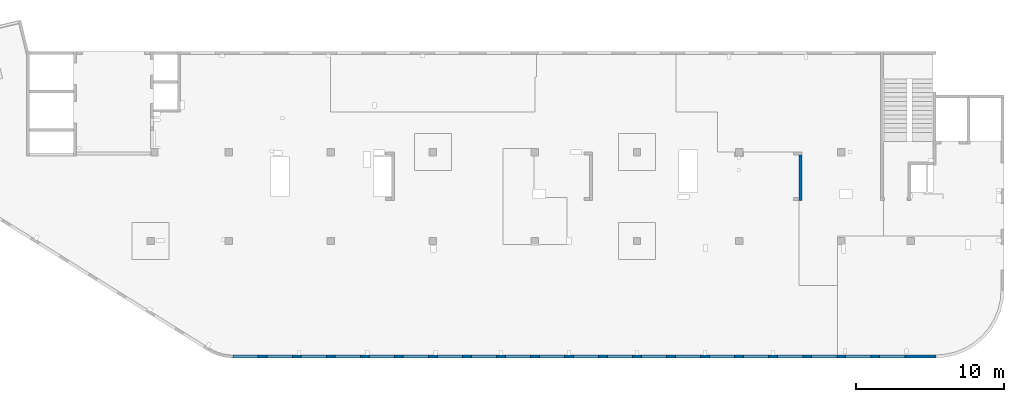
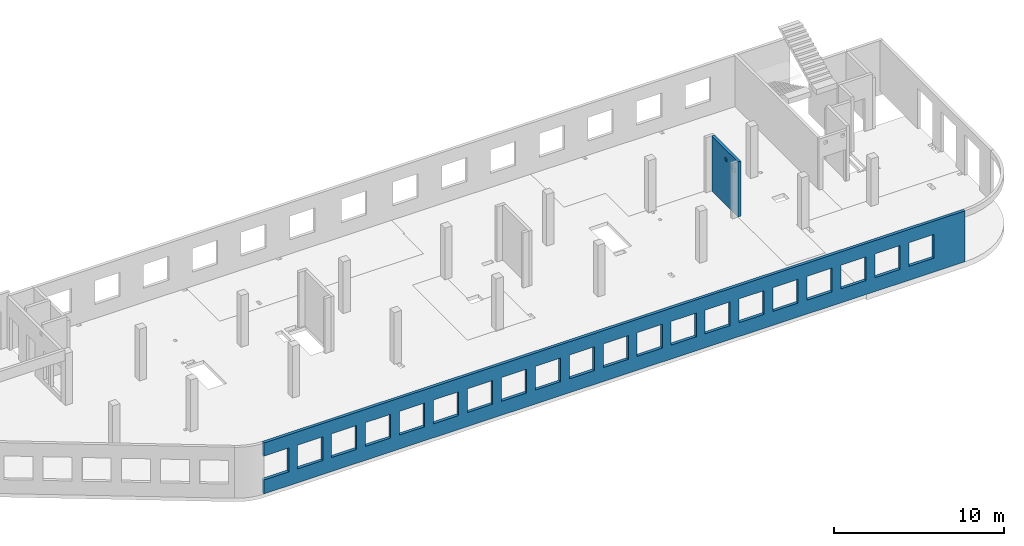
# One storey, part 5 of 6: 2 walls, 22 openings.
"""IFC4 building model written with IfcOpenShell, lengths in millimetres."""

from ifc_helpers import new_model, entity, si_unit, converted_unit, derived_unit, direction, frame, origin, place, context, subcontext, project, spatial, indexed_curve, outline, extrude, polygons, material, type_object, element, save


model = new_model("IFC4")

# Units and contexts
model_context = context("Model", 3, precision=0.01, world=origin(), true_north=direction((6.12303176911189e-17, 1.0)))
plan_context = context("Plan", 3, precision=0.01, world=origin(), true_north=direction((6.12303176911189e-17, 1.0)))
body_context = subcontext(model_context, "Body", "Model", "MODEL_VIEW")
ifc_project = project(units=[si_unit("LENGTHUNIT", "METRE", prefix="MILLI"), si_unit("AREAUNIT", "SQUARE_METRE"), si_unit("VOLUMEUNIT", "CUBIC_METRE"), converted_unit("PLANEANGLEUNIT", "DEGREE", entity("IfcRatioMeasure", 0.0174532925199433), si_unit("PLANEANGLEUNIT", "RADIAN"), dimensions=[0, 0, 0, 0, 0, 0, 0]), si_unit("MASSUNIT", "GRAM", prefix="KILO"), derived_unit("MASSDENSITYUNIT", [(si_unit("MASSUNIT", "GRAM", prefix="KILO"), 1), (si_unit("LENGTHUNIT", "METRE"), -3)]), derived_unit("MOMENTOFINERTIAUNIT", [(si_unit("LENGTHUNIT", "METRE"), 4)]), si_unit("TIMEUNIT", "SECOND"), si_unit("FREQUENCYUNIT", "HERTZ"), si_unit("THERMODYNAMICTEMPERATUREUNIT", "DEGREE_CELSIUS"), derived_unit("THERMALTRANSMITTANCEUNIT", [(si_unit("MASSUNIT", "GRAM", prefix="KILO"), 1), (si_unit("THERMODYNAMICTEMPERATUREUNIT", "KELVIN"), -1), (si_unit("TIMEUNIT", "SECOND"), -3)]), derived_unit("VOLUMETRICFLOWRATEUNIT", [(si_unit("LENGTHUNIT", "METRE"), 3), (si_unit("TIMEUNIT", "SECOND"), -1)]), derived_unit("MASSFLOWRATEUNIT", [(si_unit("MASSUNIT", "GRAM", prefix="KILO"), 1), (si_unit("TIMEUNIT", "SECOND"), -1)]), derived_unit("ROTATIONALFREQUENCYUNIT", [(si_unit("TIMEUNIT", "SECOND"), -1)]), si_unit("ELECTRICCURRENTUNIT", "AMPERE"), si_unit("ELECTRICVOLTAGEUNIT", "VOLT"), si_unit("POWERUNIT", "WATT"), si_unit("FORCEUNIT", "NEWTON", prefix="KILO"), si_unit("ILLUMINANCEUNIT", "LUX"), si_unit("LUMINOUSFLUXUNIT", "LUMEN"), si_unit("LUMINOUSINTENSITYUNIT", "CANDELA"), derived_unit("USERDEFINED", [(si_unit("MASSUNIT", "GRAM", prefix="KILO"), -1), (si_unit("LENGTHUNIT", "METRE"), -2), (si_unit("TIMEUNIT", "SECOND"), 3), (si_unit("LUMINOUSFLUXUNIT", "LUMEN"), 1)]), derived_unit("LINEARVELOCITYUNIT", [(si_unit("LENGTHUNIT", "METRE"), 1), (si_unit("TIMEUNIT", "SECOND"), -1)]), si_unit("PRESSUREUNIT", "PASCAL"), derived_unit("USERDEFINED", [(si_unit("LENGTHUNIT", "METRE"), -2), (si_unit("MASSUNIT", "GRAM", prefix="KILO"), 1), (si_unit("TIMEUNIT", "SECOND"), -2)]), derived_unit("LINEARFORCEUNIT", [(si_unit("MASSUNIT", "GRAM", prefix="KILO"), 1), (si_unit("LENGTHUNIT", "METRE"), 1), (si_unit("TIMEUNIT", "SECOND"), -2), (si_unit("LENGTHUNIT", "METRE"), -1)]), derived_unit("PLANARFORCEUNIT", [(si_unit("MASSUNIT", "GRAM", prefix="KILO"), 1), (si_unit("LENGTHUNIT", "METRE"), 1), (si_unit("TIMEUNIT", "SECOND"), -2), (si_unit("LENGTHUNIT", "METRE"), -2)])], contexts=[model_context, plan_context])

# Site, building, storey
site_placement = place(None, origin())
site = spatial("IfcSite", under=ifc_project, at=site_placement, CompositionType="ELEMENT")
building_placement = place(site_placement, origin())
building = spatial("IfcBuilding", under=site, at=building_placement, CompositionType="ELEMENT")
storey_placement = place(building_placement, frame((0.0, 0.0, 8100.0)))
storey = spatial("IfcBuildingStorey", under=building, at=storey_placement, Name="03", CompositionType="ELEMENT", Elevation=8100.0)

# Wall, openings
ifc_material = material()
wall_type = type_object("IfcWallType", Name=":ADSK_ 25_200", PredefinedType="STANDARD")
wall_1_placement = place(storey_placement, frame((68970.0, -100.0, -150.0), z_axis=(0.0, 0.0, 1.0), x_axis=(-1.0, 0.0, 0.0)))
wall_1 = element("IfcWall", 1, at=wall_1_placement, inside=storey, type_object=wall_type, material=ifc_material, Name=":ADSK_ 25_200", ObjectType=":ADSK_ 25_200", PredefinedType="NOTDEFINED", context=body_context, shape_type="Tessellation", body=[
    polygons([(43500.0, -100.000000000321, 2700.0), (45200.0, -100.000000000321, 2700.0), (45200.0, -100.000000000321, 1000.00000000001), (43500.0, -100.000000000321, 1000.00000000001), (41200.0, -100.000000000321, 2700.0), (42900.0, -100.000000000321, 2700.0), (42900.0, -100.000000000321, 1000.00000000001), (41200.0, -100.000000000321, 1000.00000000001), (38900.0, -100.000000000321, 2700.0), (40600.0, -100.000000000321, 2700.0), (40600.0, -100.000000000321, 1000.00000000001), (38900.0, -100.000000000321, 1000.00000000001), (36600.0, -100.000000000321, 2700.0), (38300.0, -100.000000000321, 2700.0), (38300.0, -100.000000000321, 1000.00000000001), (36600.0, -100.000000000321, 1000.00000000001), (34300.0, -100.000000000321, 2700.0), (36000.0, -100.000000000321, 2700.0), (36000.0, -100.000000000321, 1000.00000000001), (34300.0, -100.000000000321, 1000.00000000001), (32000.0, -100.000000000321, 2700.0), (33700.0, -100.000000000321, 2700.0), (33700.0, -100.000000000321, 1000.00000000001), (32000.0, -100.000000000321, 1000.00000000001), (29700.0, -100.000000000321, 2700.0), (31400.0, -100.000000000321, 2700.0), (31400.0, -100.000000000321, 1000.00000000001), (29700.0, -100.000000000321, 1000.00000000001), (27400.0, -100.000000000321, 2700.0), (29100.0, -100.000000000321, 2700.0), (29100.0, -100.000000000321, 1000.00000000001), (27400.0, -100.000000000321, 1000.00000000001), (25100.0, -100.000000000321, 2700.0), (26800.0, -100.000000000321, 2700.0), (26800.0, -100.000000000321, 1000.00000000001), (25100.0, -100.000000000321, 1000.00000000001), (22800.0, -100.000000000321, 2700.0), (24500.0, -100.000000000321, 2700.0), (24500.0, -100.000000000321, 1000.00000000001), (22800.0, -100.000000000321, 1000.00000000001), (20500.0, -100.000000000321, 2700.0), (22200.0, -100.000000000321, 2700.0), (22200.0, -100.000000000321, 1000.00000000001), (20500.0, -100.000000000321, 1000.00000000001), (18200.0, -100.000000000321, 2700.0), (19900.0, -100.000000000321, 2700.0), (19900.0, -100.000000000321, 1000.00000000001), (18200.0, -100.000000000321, 1000.00000000001), (15900.0, -100.000000000321, 2700.0), (17600.0, -100.000000000321, 2700.0), (17600.0, -100.000000000321, 1000.00000000001), (15900.0, -100.000000000321, 1000.00000000001), (13600.0, -100.000000000321, 2700.0), (15300.0, -100.000000000321, 2700.0), (15300.0, -100.000000000321, 1000.00000000001), (13600.0, -100.000000000321, 1000.00000000001), (11300.0, -100.000000000321, 2700.0), (13000.0, -100.000000000321, 2700.0), (13000.0, -100.000000000321, 1000.00000000001), (11300.0, -100.000000000321, 1000.00000000001), (8999.99999999998, -100.000000000321, 2700.0), (10700.0, -100.000000000321, 2700.0), (10700.0, -100.000000000321, 1000.00000000001), (8999.99999999998, -100.000000000321, 1000.00000000001), (6699.99999999998, -100.000000000321, 2700.0), (8399.99999999997, -100.000000000321, 2700.0), (8399.99999999997, -100.000000000321, 1000.00000000001), (6699.99999999998, -100.000000000321, 1000.00000000001), (4399.99999999998, -100.000000000321, 2700.0), (6099.99999999997, -100.000000000321, 2700.0), (6099.99999999997, -100.000000000321, 1000.00000000001), (4399.99999999998, -100.000000000321, 1000.00000000001), (2099.99999999998, -100.000000000321, 2700.0), (3799.99999999998, -100.000000000321, 2700.0), (3799.99999999998, -100.000000000321, 1000.00000000001), (2099.99999999998, -100.000000000321, 1000.00000000001), (8.66293717728731e-12, -100.0, 0.0), (10900.0003342008, -100.0, 0.0), (11100.0003342008, -100.0, 0.0), (15500.0003342008, -100.0, 0.0), (15700.0003342008, -100.0, 0.0), (20100.0, -100.0, 0.0), (20300.0, -100.0, 0.0), (24700.0003342008, -100.0, 0.0), (24900.0003342008, -100.0, 0.0), (38320.0003342008, -100.0, 0.0), (38520.0003342008, -100.0, 0.0), (42930.0, -100.0, 0.0), (43130.0, -100.0, 0.0), (47500.0, -100.0, 0.0), (47500.0, -100.0, 1000.00000000001), (45800.0, -100.000000000321, 1000.00000000001), (45800.0, -100.000000000321, 2700.0), (47500.0, -100.0, 2700.0), (47500.0, -100.0, 3650.0), (8.66293717728731e-12, -100.0, 3650.0), (1.42900165493394e-19, -100.0, 3200.0), (47500.0, 100.0, 0.0), (8.01671852045731e-12, 100.0, 0.0), (-6.46218513929826e-13, 100.0, 3200.0), (8.01671852045731e-12, 100.0, 3650.0), (47500.0, 100.0, 3650.0), (47500.0, 100.0, 2700.0), (45800.0, 100.0, 2700.0), (45800.0, 100.0, 1000.00000000001), (47500.0, 100.0, 1000.00000000001), (45200.0, 100.0, 2700.0), (43500.0, 100.0, 2700.0), (43500.0, 100.0, 1000.00000000001), (45200.0, 100.0, 1000.00000000001), (42900.0, 100.0, 2700.0), (41200.0, 100.0, 2700.0), (41200.0, 100.0, 1000.00000000001), (42900.0, 100.0, 1000.00000000001), (40600.0, 100.0, 2700.0), (38900.0, 100.0, 2700.0), (38900.0, 100.0, 1000.00000000001), (40600.0, 100.0, 1000.00000000001), (38300.0, 100.0, 2700.0), (36600.0, 100.0, 2700.0), (36600.0, 100.0, 1000.00000000001), (38300.0, 100.0, 1000.00000000001), (36000.0, 100.0, 2700.0), (34300.0, 100.0, 2700.0), (34300.0, 100.0, 1000.00000000001), (36000.0, 100.0, 1000.00000000001), (33700.0, 100.0, 2700.0), (32000.0, 100.0, 2700.0), (32000.0, 100.0, 1000.00000000001), (33700.0, 100.0, 1000.00000000001), (31400.0, 100.0, 2700.0), (29700.0, 100.0, 2700.0), (29700.0, 100.0, 1000.00000000001), (31400.0, 100.0, 1000.00000000001), (29100.0, 100.0, 2700.0), (27400.0, 100.0, 2700.0), (27400.0, 100.0, 1000.00000000001), (29100.0, 100.0, 1000.00000000001), (26800.0, 100.0, 2700.0), (25100.0, 100.0, 2700.0), (25100.0, 100.0, 1000.00000000001), (26800.0, 100.0, 1000.00000000001), (24500.0, 100.0, 2700.0), (22800.0, 100.0, 2700.0), (22800.0, 100.0, 1000.00000000001), (24500.0, 100.0, 1000.00000000001), (22200.0, 100.0, 2700.0), (20500.0, 100.0, 2700.0), (20500.0, 100.0, 1000.00000000001), (22200.0, 100.0, 1000.00000000001), (19900.0, 100.0, 2700.0), (18200.0, 100.0, 2700.0), (18200.0, 100.0, 1000.00000000001), (19900.0, 100.0, 1000.00000000001), (17600.0, 100.0, 2700.0), (15900.0, 100.0, 2700.0), (15900.0, 100.0, 1000.00000000001), (17600.0, 100.0, 1000.00000000001), (15300.0, 100.0, 2700.0), (13600.0, 100.0, 2700.0), (13600.0, 100.0, 1000.00000000001), (15300.0, 100.0, 1000.00000000001), (13000.0, 100.0, 2700.0), (11300.0, 100.0, 2700.0), (11300.0, 100.0, 1000.00000000001), (13000.0, 100.0, 1000.00000000001), (10700.0, 100.0, 2700.0), (8999.99999999998, 100.0, 2700.0), (8999.99999999998, 100.0, 1000.00000000001), (10700.0, 100.0, 1000.00000000001), (8399.99999999997, 100.0, 2700.0), (6699.99999999997, 100.0, 2700.0), (6699.99999999997, 100.0, 1000.00000000001), (8399.99999999997, 100.0, 1000.00000000001), (6099.99999999997, 100.0, 2700.0), (4399.99999999998, 100.0, 2700.0), (4399.99999999998, 100.0, 1000.00000000001), (6099.99999999997, 100.0, 1000.00000000001), (3799.99999999998, 100.0, 2700.0), (2099.99999999998, 100.0, 2700.0), (2099.99999999998, 100.0, 1000.00000000001), (3799.99999999998, 100.0, 1000.00000000001)], [[[77, 78, 79, 80, 81, 82, 83, 84, 85, 86, 87, 88, 89, 90, 91, 92, 93, 94, 95, 96, 97], [1, 2, 3, 4], [5, 6, 7, 8], [9, 10, 11, 12], [13, 14, 15, 16], [17, 18, 19, 20], [21, 22, 23, 24], [25, 26, 27, 28], [29, 30, 31, 32], [33, 34, 35, 36], [37, 38, 39, 40], [41, 42, 43, 44], [45, 46, 47, 48], [49, 50, 51, 52], [53, 54, 55, 56], [57, 58, 59, 60], [61, 62, 63, 64], [65, 66, 67, 68], [69, 70, 71, 72], [73, 74, 75, 76]], [[98, 99, 100, 101, 102, 103, 104, 105, 106], [107, 108, 109, 110], [111, 112, 113, 114], [115, 116, 117, 118], [119, 120, 121, 122], [123, 124, 125, 126], [127, 128, 129, 130], [131, 132, 133, 134], [135, 136, 137, 138], [139, 140, 141, 142], [143, 144, 145, 146], [147, 148, 149, 150], [151, 152, 153, 154], [155, 156, 157, 158], [159, 160, 161, 162], [163, 164, 165, 166], [167, 168, 169, 170], [171, 172, 173, 174], [175, 176, 177, 178], [179, 180, 181, 182]], [[90, 89, 88, 87, 86, 85, 84, 83, 82, 81, 80, 79, 78, 77, 99, 98]], [[90, 98, 106, 91]], [[96, 95, 102, 101]], [[77, 97, 96, 101, 100, 99]], [[93, 104, 103, 94]], [[105, 92, 91, 106]], [[104, 93, 92, 105]], [[2, 1, 108, 107]], [[2, 107, 110, 3]], [[3, 110, 109, 4]], [[108, 1, 4, 109]], [[6, 5, 112, 111]], [[6, 111, 114, 7]], [[7, 114, 113, 8]], [[112, 5, 8, 113]], [[10, 9, 116, 115]], [[10, 115, 118, 11]], [[11, 118, 117, 12]], [[116, 9, 12, 117]], [[14, 13, 120, 119]], [[14, 119, 122, 15]], [[15, 122, 121, 16]], [[120, 13, 16, 121]], [[18, 17, 124, 123]], [[18, 123, 126, 19]], [[19, 126, 125, 20]], [[124, 17, 20, 125]], [[22, 21, 128, 127]], [[22, 127, 130, 23]], [[23, 130, 129, 24]], [[128, 21, 24, 129]], [[26, 25, 132, 131]], [[26, 131, 134, 27]], [[27, 134, 133, 28]], [[132, 25, 28, 133]], [[30, 29, 136, 135]], [[30, 135, 138, 31]], [[31, 138, 137, 32]], [[136, 29, 32, 137]], [[34, 33, 140, 139]], [[34, 139, 142, 35]], [[35, 142, 141, 36]], [[140, 33, 36, 141]], [[38, 37, 144, 143]], [[38, 143, 146, 39]], [[39, 146, 145, 40]], [[144, 37, 40, 145]], [[42, 41, 148, 147]], [[42, 147, 150, 43]], [[43, 150, 149, 44]], [[148, 41, 44, 149]], [[46, 45, 152, 151]], [[46, 151, 154, 47]], [[47, 154, 153, 48]], [[152, 45, 48, 153]], [[50, 49, 156, 155]], [[50, 155, 158, 51]], [[51, 158, 157, 52]], [[156, 49, 52, 157]], [[54, 53, 160, 159]], [[54, 159, 162, 55]], [[55, 162, 161, 56]], [[160, 53, 56, 161]], [[58, 57, 164, 163]], [[58, 163, 166, 59]], [[59, 166, 165, 60]], [[164, 57, 60, 165]], [[62, 61, 168, 167]], [[62, 167, 170, 63]], [[63, 170, 169, 64]], [[168, 61, 64, 169]], [[66, 65, 172, 171]], [[66, 171, 174, 67]], [[67, 174, 173, 68]], [[172, 65, 68, 173]], [[70, 69, 176, 175]], [[70, 175, 178, 71]], [[71, 178, 177, 72]], [[176, 69, 72, 177]], [[74, 73, 180, 179]], [[74, 179, 182, 75]], [[75, 182, 181, 76]], [[180, 73, 76, 181]], [[102, 95, 94, 103]]], closed=True),
])
placement_1 = place(wall_1_placement, frame((68970.0, -100.0, 150.0), z_axis=(0.0, 0.0, 1.0), x_axis=(-1.0, 0.0, 0.0)))
element("IfcOpeningElement", 2, at=placement_1, cuts=wall_1, Name=":ADSK_ 25_200", PredefinedType="OPENING", context=body_context, shape_type="SweptSolid", body=[
    extrude(outline(indexed_curve([(-850.000000000002, -849.999999999995), (849.999999999997, -849.999999999995), (849.999999999997, 849.999999999993), (-850.000000000002, 849.999999999993), (-850.000000000002, -849.999999999995)], self_intersect=False)), frame((22320.0, 0.0, 1700.0), z_axis=(0.0, -1.0, 0.0), x_axis=(-1.0, 0.0, 0.0)), (0.0, 0.0, 1.0), 200.000000000962),
])
element("IfcOpeningElement", 3, at=placement_1, cuts=wall_1, Name=":ADSK_ 25_200", PredefinedType="OPENING", context=body_context, shape_type="SweptSolid", body=[
    extrude(outline(indexed_curve([(-849.999999999997, -849.999999999995), (850.000000000006, -849.999999999995), (850.000000000006, 849.999999999993), (-849.999999999997, 849.999999999993), (-849.999999999997, -849.999999999995)], self_intersect=False)), frame((66020.0, 0.0, 1700.0), z_axis=(0.0, -1.0, 0.0), x_axis=(-1.0, 0.0, 0.0)), (0.0, 0.0, 1.0), 200.000000000962),
])
element("IfcOpeningElement", 4, at=placement_1, cuts=wall_1, Name=":ADSK_ 25_200", PredefinedType="OPENING", context=body_context, shape_type="SweptSolid", body=[
    extrude(outline(indexed_curve([(-849.999999999997, -849.999999999995), (850.000000000006, -849.999999999995), (850.000000000006, 849.999999999993), (-849.999999999997, 849.999999999993), (-849.999999999997, -849.999999999995)], self_intersect=False)), frame((63720.0, 0.0, 1700.0), z_axis=(0.0, -1.0, 0.0), x_axis=(-1.0, 0.0, 0.0)), (0.0, 0.0, 1.0), 200.000000000962),
])
element("IfcOpeningElement", 5, at=placement_1, cuts=wall_1, Name=":ADSK_ 25_200", PredefinedType="OPENING", context=body_context, shape_type="SweptSolid", body=[
    extrude(outline(indexed_curve([(-849.999999999997, -849.999999999995), (850.000000000006, -849.999999999995), (850.000000000006, 849.999999999993), (-849.999999999997, 849.999999999993), (-849.999999999997, -849.999999999995)], self_intersect=False)), frame((61420.0, 0.0, 1700.0), z_axis=(0.0, -1.0, 0.0), x_axis=(-1.0, 0.0, 0.0)), (0.0, 0.0, 1.0), 200.000000000962),
])
element("IfcOpeningElement", 6, at=placement_1, cuts=wall_1, Name=":ADSK_ 25_200", PredefinedType="OPENING", context=body_context, shape_type="SweptSolid", body=[
    extrude(outline(indexed_curve([(-849.999999999997, -849.999999999995), (850.000000000006, -849.999999999995), (850.000000000006, 849.999999999993), (-849.999999999997, 849.999999999993), (-849.999999999997, -849.999999999995)], self_intersect=False)), frame((59120.0, 0.0, 1700.0), z_axis=(0.0, -1.0, 0.0), x_axis=(-1.0, 0.0, 0.0)), (0.0, 0.0, 1.0), 200.000000000962),
])
element("IfcOpeningElement", 7, at=placement_1, cuts=wall_1, Name=":ADSK_ 25_200", PredefinedType="OPENING", context=body_context, shape_type="SweptSolid", body=[
    extrude(outline(indexed_curve([(-849.999999999997, -849.999999999995), (850.000000000006, -849.999999999995), (850.000000000006, 849.999999999993), (-849.999999999997, 849.999999999993), (-849.999999999997, -849.999999999995)], self_intersect=False)), frame((56820.0, 0.0, 1700.0), z_axis=(0.0, -1.0, 0.0), x_axis=(-1.0, 0.0, 0.0)), (0.0, 0.0, 1.0), 200.000000000962),
])
element("IfcOpeningElement", 8, at=placement_1, cuts=wall_1, Name=":ADSK_ 25_200", PredefinedType="OPENING", context=body_context, shape_type="SweptSolid", body=[
    extrude(outline(indexed_curve([(-849.999999999997, -849.999999999995), (850.000000000006, -849.999999999995), (850.000000000006, 849.999999999993), (-849.999999999997, 849.999999999993), (-849.999999999997, -849.999999999995)], self_intersect=False)), frame((54520.0, 0.0, 1700.0), z_axis=(0.0, -1.0, 0.0), x_axis=(-1.0, 0.0, 0.0)), (0.0, 0.0, 1.0), 200.000000000962),
])
element("IfcOpeningElement", 9, at=placement_1, cuts=wall_1, Name=":ADSK_ 25_200", PredefinedType="OPENING", context=body_context, shape_type="SweptSolid", body=[
    extrude(outline(indexed_curve([(-849.999999999997, -849.999999999995), (850.000000000006, -849.999999999995), (850.000000000006, 849.999999999993), (-849.999999999997, 849.999999999993), (-849.999999999997, -849.999999999995)], self_intersect=False)), frame((52220.0, 0.0, 1700.0), z_axis=(0.0, -1.0, 0.0), x_axis=(-1.0, 0.0, 0.0)), (0.0, 0.0, 1.0), 200.000000000962),
])
element("IfcOpeningElement", 10, at=placement_1, cuts=wall_1, Name=":ADSK_ 25_200", PredefinedType="OPENING", context=body_context, shape_type="SweptSolid", body=[
    extrude(outline(indexed_curve([(-849.999999999997, -849.999999999995), (850.000000000006, -849.999999999995), (850.000000000006, 849.999999999993), (-849.999999999997, 849.999999999993), (-849.999999999997, -849.999999999995)], self_intersect=False)), frame((49920.0, 0.0, 1700.0), z_axis=(0.0, -1.0, 0.0), x_axis=(-1.0, 0.0, 0.0)), (0.0, 0.0, 1.0), 200.000000000962),
])
element("IfcOpeningElement", 11, at=placement_1, cuts=wall_1, Name=":ADSK_ 25_200", PredefinedType="OPENING", context=body_context, shape_type="SweptSolid", body=[
    extrude(outline(indexed_curve([(-849.999999999997, -849.999999999995), (850.000000000006, -849.999999999995), (850.000000000006, 849.999999999993), (-849.999999999997, 849.999999999993), (-849.999999999997, -849.999999999995)], self_intersect=False)), frame((47620.0, 0.0, 1700.0), z_axis=(0.0, -1.0, 0.0), x_axis=(-1.0, 0.0, 0.0)), (0.0, 0.0, 1.0), 200.000000000962),
])
element("IfcOpeningElement", 12, at=placement_1, cuts=wall_1, Name=":ADSK_ 25_200", PredefinedType="OPENING", context=body_context, shape_type="SweptSolid", body=[
    extrude(outline(indexed_curve([(-849.999999999997, -849.999999999995), (850.000000000006, -849.999999999995), (850.000000000006, 849.999999999993), (-849.999999999997, 849.999999999993), (-849.999999999997, -849.999999999995)], self_intersect=False)), frame((45320.0, 0.0, 1700.0), z_axis=(0.0, -1.0, 0.0), x_axis=(-1.0, 0.0, 0.0)), (0.0, 0.0, 1.0), 200.000000000962),
])
element("IfcOpeningElement", 13, at=placement_1, cuts=wall_1, Name=":ADSK_ 25_200", PredefinedType="OPENING", context=body_context, shape_type="SweptSolid", body=[
    extrude(outline(indexed_curve([(-849.999999999997, -849.999999999995), (850.000000000006, -849.999999999995), (850.000000000006, 849.999999999993), (-849.999999999997, 849.999999999993), (-849.999999999997, -849.999999999995)], self_intersect=False)), frame((43020.0, 0.0, 1700.0), z_axis=(0.0, -1.0, 0.0), x_axis=(-1.0, 0.0, 0.0)), (0.0, 0.0, 1.0), 200.000000000962),
])
element("IfcOpeningElement", 14, at=placement_1, cuts=wall_1, Name=":ADSK_ 25_200", PredefinedType="OPENING", context=body_context, shape_type="SweptSolid", body=[
    extrude(outline(indexed_curve([(-849.999999999997, -849.999999999995), (850.000000000006, -849.999999999995), (850.000000000006, 849.999999999993), (-849.999999999997, 849.999999999993), (-849.999999999997, -849.999999999995)], self_intersect=False)), frame((40720.0, 0.0, 1700.0), z_axis=(0.0, -1.0, 0.0), x_axis=(-1.0, 0.0, 0.0)), (0.0, 0.0, 1.0), 200.000000000962),
])
element("IfcOpeningElement", 15, at=placement_1, cuts=wall_1, Name=":ADSK_ 25_200", PredefinedType="OPENING", context=body_context, shape_type="SweptSolid", body=[
    extrude(outline(indexed_curve([(-849.999999999997, -849.999999999995), (850.000000000002, -849.999999999995), (850.000000000002, 849.999999999993), (-849.999999999997, 849.999999999993), (-849.999999999997, -849.999999999995)], self_intersect=False)), frame((38420.0, 0.0, 1700.0), z_axis=(0.0, -1.0, 0.0), x_axis=(-1.0, 0.0, 0.0)), (0.0, 0.0, 1.0), 200.000000000962),
])
element("IfcOpeningElement", 16, at=placement_1, cuts=wall_1, Name=":ADSK_ 25_200", PredefinedType="OPENING", context=body_context, shape_type="SweptSolid", body=[
    extrude(outline(indexed_curve([(-849.999999999997, -849.999999999995), (850.000000000002, -849.999999999995), (850.000000000002, 849.999999999993), (-849.999999999997, 849.999999999993), (-849.999999999997, -849.999999999995)], self_intersect=False)), frame((36120.0, 0.0, 1700.0), z_axis=(0.0, -1.0, 0.0), x_axis=(-1.0, 0.0, 0.0)), (0.0, 0.0, 1.0), 200.000000000962),
])
element("IfcOpeningElement", 17, at=placement_1, cuts=wall_1, Name=":ADSK_ 25_200", PredefinedType="OPENING", context=body_context, shape_type="SweptSolid", body=[
    extrude(outline(indexed_curve([(-849.999999999997, -849.999999999995), (850.000000000002, -849.999999999995), (850.000000000002, 849.999999999993), (-849.999999999997, 849.999999999993), (-849.999999999997, -849.999999999995)], self_intersect=False)), frame((33820.0, 0.0, 1700.0), z_axis=(0.0, -1.0, 0.0), x_axis=(-1.0, 0.0, 0.0)), (0.0, 0.0, 1.0), 200.000000000962),
])
element("IfcOpeningElement", 18, at=placement_1, cuts=wall_1, Name=":ADSK_ 25_200", PredefinedType="OPENING", context=body_context, shape_type="SweptSolid", body=[
    extrude(outline(indexed_curve([(-849.999999999997, -849.999999999995), (850.000000000002, -849.999999999995), (850.000000000002, 849.999999999993), (-849.999999999997, 849.999999999993), (-849.999999999997, -849.999999999995)], self_intersect=False)), frame((31520.0, 0.0, 1700.0), z_axis=(0.0, -1.0, 0.0), x_axis=(-1.0, 0.0, 0.0)), (0.0, 0.0, 1.0), 200.000000000962),
])
element("IfcOpeningElement", 19, at=placement_1, cuts=wall_1, Name=":ADSK_ 25_200", PredefinedType="OPENING", context=body_context, shape_type="SweptSolid", body=[
    extrude(outline(indexed_curve([(-850.000000000002, -849.999999999995), (849.999999999997, -849.999999999995), (849.999999999997, 849.999999999993), (-850.000000000002, 849.999999999993), (-850.000000000002, -849.999999999995)], self_intersect=False)), frame((29220.0, 0.0, 1700.0), z_axis=(0.0, -1.0, 0.0), x_axis=(-1.0, 0.0, 0.0)), (0.0, 0.0, 1.0), 200.000000000962),
])
element("IfcOpeningElement", 20, at=placement_1, cuts=wall_1, Name=":ADSK_ 25_200", PredefinedType="OPENING", context=body_context, shape_type="SweptSolid", body=[
    extrude(outline(indexed_curve([(-850.000000000002, -849.999999999995), (849.999999999997, -849.999999999995), (849.999999999997, 849.999999999993), (-850.000000000002, 849.999999999993), (-850.000000000002, -849.999999999995)], self_intersect=False)), frame((26920.0, 0.0, 1700.0), z_axis=(0.0, -1.0, 0.0), x_axis=(-1.0, 0.0, 0.0)), (0.0, 0.0, 1.0), 200.000000000962),
])
element("IfcOpeningElement", 21, at=placement_1, cuts=wall_1, Name=":ADSK_ 25_200", PredefinedType="OPENING", context=body_context, shape_type="SweptSolid", body=[
    extrude(outline(indexed_curve([(-850.000000000002, -849.999999999995), (849.999999999997, -849.999999999995), (849.999999999997, 849.999999999993), (-850.000000000002, 849.999999999993), (-850.000000000002, -849.999999999995)], self_intersect=False)), frame((24620.0, 0.0, 1700.0), z_axis=(0.0, -1.0, 0.0), x_axis=(-1.0, 0.0, 0.0)), (0.0, 0.0, 1.0), 200.000000000962),
])

wall_2_placement = place(storey_placement, frame((59830.0, 13500.0, -150.0), z_axis=(0.0, 0.0, 1.0), x_axis=(0.0, -1.0, 0.0)))
wall_2 = element("IfcWall", 22, at=wall_2_placement, inside=storey, type_object=wall_type, material=ifc_material, Name=":ADSK_ 25_200", ObjectType=":ADSK_ 25_200", PredefinedType="NOTDEFINED", context=body_context, shape_type="Tessellation", body=[
    polygons([(-2.16573425859679e-12, -99.999999999987, 0.0), (2875.00000000001, -99.9999999999967, 0.0), (3075.00000000001, -99.9999999999962, 0.0), (3075.00000000001, -99.9999999999962, 3950.0), (2875.00000000001, -99.9999999999967, 3950.0), (-2.16573425859679e-12, -99.999999999987, 3950.0), (1560.00000000001, -100.000000000009, 3400.0), (1810.00000000001, -100.000000000008, 3400.0), (1810.00000000001, -100.000000000008, 3150.00000000001), (1560.00000000001, -100.000000000009, 3150.00000000001), (2360.00000000001, -100.000000000007, 3330.0), (2710.00000000001, -100.000000000006, 3330.0), (2710.00000000001, -100.000000000006, 2980.00000000001), (2360.00000000001, -100.000000000007, 2980.00000000001), (-2.16573425859679e-12, 100.000000000002, 0.0), (-2.16573425859679e-12, 100.000000000002, 3950.0), (3075.00000000001, 99.999999999993, 3950.0), (3075.00000000001, 99.999999999993, 0.0), (1810.00000000001, 100.000000000319, 3400.0), (1560.00000000001, 100.000000000318, 3400.0), (1560.00000000001, 100.000000000318, 3150.00000000001), (1810.00000000001, 100.000000000319, 3150.00000000001), (2710.00000000001, 100.000000000321, 3330.0), (2360.00000000001, 100.00000000032, 3330.0), (2360.00000000001, 100.00000000032, 2980.00000000001), (2710.00000000001, 100.000000000321, 2980.00000000001)], [[[1, 2, 3, 4, 5, 6], [7, 8, 9, 10], [11, 12, 13, 14]], [[15, 16, 17, 18], [19, 20, 21, 22], [23, 24, 25, 26]], [[3, 2, 1, 15, 18]], [[6, 5, 4, 17, 16]], [[1, 6, 16, 15]], [[4, 3, 18, 17]], [[20, 19, 8, 7]], [[20, 7, 10, 21]], [[21, 10, 9, 22]], [[8, 19, 22, 9]], [[24, 23, 12, 11]], [[24, 11, 14, 25]], [[25, 14, 13, 26]], [[12, 23, 26, 13]]], closed=True),
])
placement_2 = place(wall_2_placement, frame((13500.0, -59830.0, 150.0), z_axis=(0.0, 0.0, 1.0), x_axis=(0.0, 1.0, 0.0)))
element("IfcOpeningElement", 23, at=placement_2, cuts=wall_2, Name=":ADSK_ 25_200", PredefinedType="OPENING", context=body_context, shape_type="SweptSolid", body=[
    extrude(outline(indexed_curve([(-174.999999999993, -174.999999999999), (174.999999999993, -174.999999999999), (174.999999999993, 175.000000000001), (-174.999999999993, 175.000000000001), (-174.999999999993, -174.999999999999)], self_intersect=False)), frame((59730.0, 10965.0, 3005.0), z_axis=(1.0, 0.0, 0.0), x_axis=(0.0, 0.0, -1.0)), (0.0, 0.0, 1.0), 200.000000000968),
])
element("IfcOpeningElement", 24, at=placement_2, cuts=wall_2, Name=":ADSK_ 25_200", PredefinedType="OPENING", context=body_context, shape_type="SweptSolid", body=[
    extrude(outline(indexed_curve([(-124.999999999991, -125.0), (124.999999999993, -125.0), (124.999999999993, 125.0), (-124.999999999991, 125.0), (-124.999999999991, -125.0)], self_intersect=False)), frame((59730.0, 11815.0, 3125.0), z_axis=(1.0, 0.0, 0.0), x_axis=(0.0, 0.0, -1.0)), (0.0, 0.0, 1.0), 200.000000000968),
])

save(model, "model.ifc")
